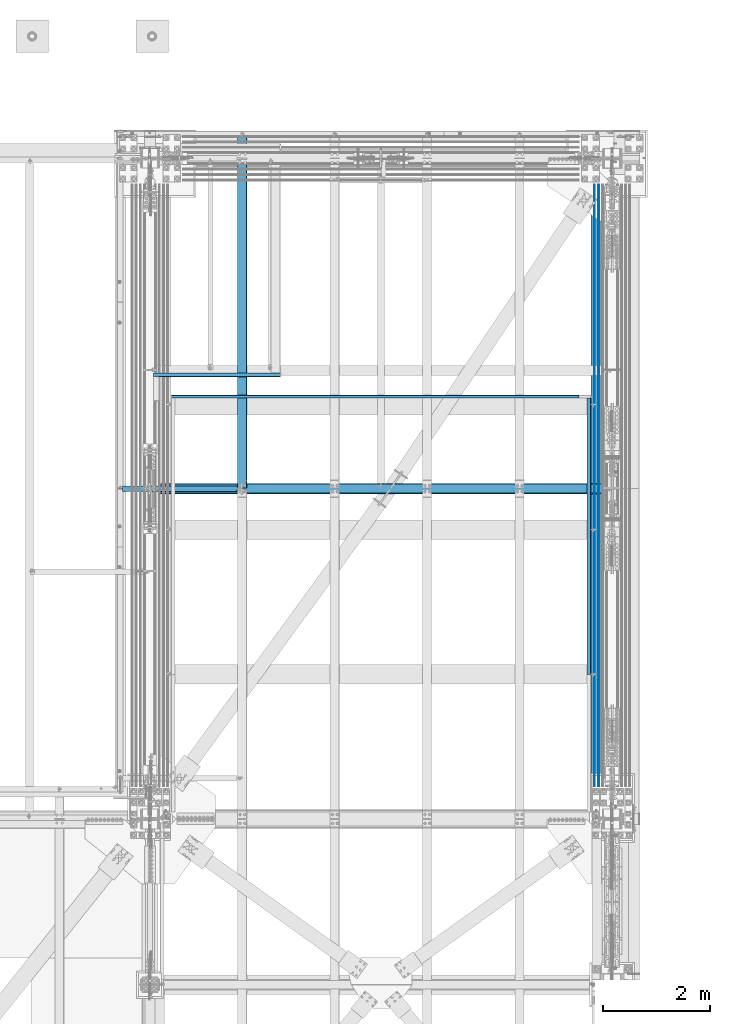
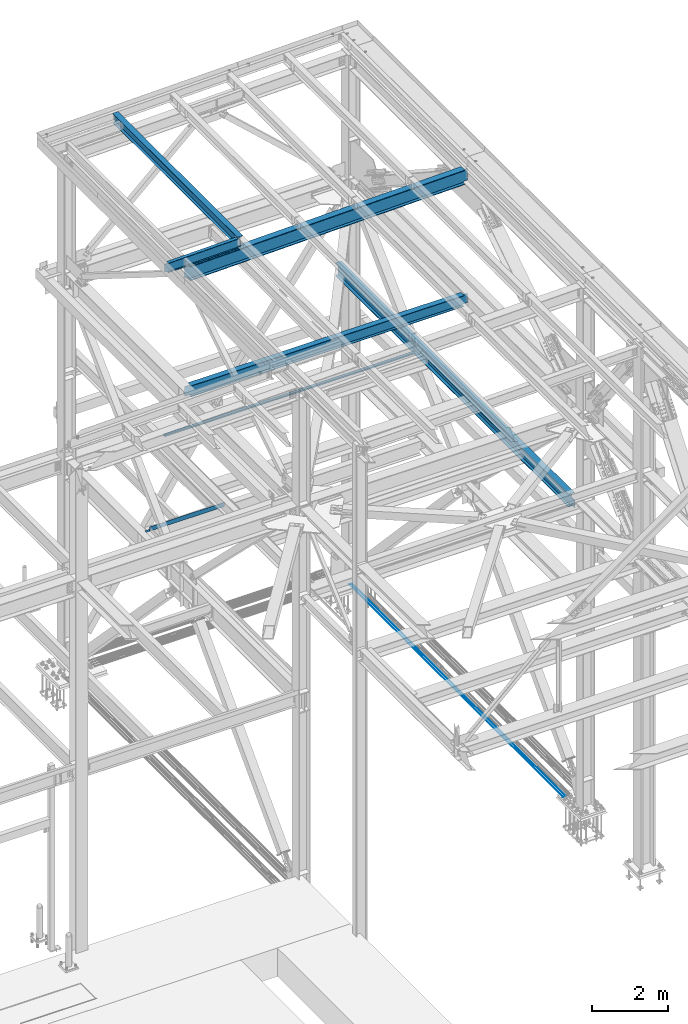
# One storey, part 1993 of 3843: 10 beams, 10 elements without a shape of their own.
"""IFC2X3 building model written with IfcOpenShell, lengths in millimetres."""

from ifc_helpers import new_model, si_unit, frame, origin_with_axes, place, context, subcontext, project, spatial, faceted_brep, material, type_object, element, aggregate, save


model = new_model("IFC2X3")

# Units and contexts
model_context = context("Model", 3, precision=1e-05, world=origin_with_axes())
body_context = subcontext(model_context, "Body", "Model", "MODEL_VIEW")
ifc_project = project(units=[si_unit("LENGTHUNIT", "METRE", prefix="MILLI"), si_unit("AREAUNIT", "SQUARE_METRE"), si_unit("VOLUMEUNIT", "CUBIC_METRE"), si_unit("MASSUNIT", "GRAM", prefix="KILO"), si_unit("TIMEUNIT", "SECOND"), si_unit("PLANEANGLEUNIT", "RADIAN"), si_unit("SOLIDANGLEUNIT", "STERADIAN"), si_unit("THERMODYNAMICTEMPERATUREUNIT", "DEGREE_CELSIUS"), si_unit("LUMINOUSINTENSITYUNIT", "LUMEN")], contexts=[model_context])

# Site, building, storey
site_placement = place(None, origin_with_axes())
site = spatial("IfcSite", under=ifc_project, at=site_placement, CompositionType="ELEMENT")
building_placement = place(site_placement, origin_with_axes())
building = spatial("IfcBuilding", under=site, at=building_placement, Name="Undefined", CompositionType="ELEMENT")
storey_placement = place(building_placement, origin_with_axes())
storey = spatial("IfcBuildingStorey", under=building, at=storey_placement, Name="Undefined", CompositionType="ELEMENT", Elevation=0.0)

# Assembly, beam
assembly_1_placement = place(storey_placement, origin_with_axes())
assembly_1 = element("IfcElementAssembly", 1, at=assembly_1_placement, inside=storey, Name="REBAR", AssemblyPlace="NOTDEFINED", PredefinedType="RIGID_FRAME")
ifc_material_1 = material(Name="STEEL/A706-60")
beam_type_1 = type_object("IfcBeamType", Name="#10 REBAR", PredefinedType="NOTDEFINED")
beam_1_placement = place(assembly_1_placement, frame((85318.6, 104063.800019533, 29700.5375), z_axis=(0.0, 0.0, 1.0), x_axis=(0.0, -1.0, 0.0)))
beam_1 = element("IfcBeam", 2, at=beam_1_placement, type_object=beam_type_1, material=ifc_material_1, Name="REBAR", ObjectType="#10 REBAR", context=body_context, shape_type="Brep", body=[
    faceted_brep([(0.0, -7.9375, 0.0), (0.0, -5.61266007566883, -5.61266007566883), (11239.5874999941, -5.61266007566883, -5.61266007566883), (11239.5874999941, -7.9375, 0.0), (0.0, 0.0, -7.9375), (11239.5874999941, 0.0, -7.9375), (0.0, 5.61266007566883, -5.61266007566883), (11239.5874999941, 5.61266007566883, -5.61266007566883), (0.0, 7.9375, 0.0), (11239.5874999941, 7.9375, 0.0), (0.0, 5.61266007566883, 5.61266007566883), (11239.5874999941, 5.61266007566883, 5.61266007566883), (0.0, 0.0, 7.9375), (11239.5874999941, 0.0, 7.9375), (0.0, -5.61266007566883, 5.61266007566883), (11239.5874999941, -5.61266007566883, 5.61266007566883)], [[[0, 1, 2, 3]], [[1, 4, 5, 2]], [[4, 6, 7, 5]], [[6, 8, 9, 7]], [[8, 10, 11, 9]], [[10, 12, 13, 11]], [[12, 14, 15, 13]], [[14, 0, 3, 15]], [[5, 7, 9, 11, 13, 15, 3, 2]], [[14, 12, 10, 8, 6, 4, 1, 0]]]),
])
aggregate(assembly_1, [beam_1])

assembly_2_placement = place(storey_placement, origin_with_axes())
assembly_2 = element("IfcElementAssembly", 3, at=assembly_2_placement, inside=storey, Name="REBAR", AssemblyPlace="NOTDEFINED", PredefinedType="RIGID_FRAME")
beam_2_placement = place(assembly_2_placement, frame((85394.8, 104063.800019533, 29700.5375), z_axis=(0.0, 0.0, 1.0), x_axis=(0.0, -1.0, 0.0)))
beam_2 = element("IfcBeam", 4, at=beam_2_placement, type_object=beam_type_1, material=ifc_material_1, Name="REBAR", ObjectType="#10 REBAR", context=body_context, shape_type="Brep", body=[
    faceted_brep([(0.0, -7.9375, 0.0), (0.0, -5.61266007566883, -5.61266007566883), (11239.5874999941, -5.61266007566883, -5.61266007566883), (11239.5874999941, -7.9375, 0.0), (0.0, 0.0, -7.9375), (11239.5874999941, 0.0, -7.9375), (0.0, 5.61266007566883, -5.61266007566883), (11239.5874999941, 5.61266007566883, -5.61266007566883), (0.0, 7.9375, 0.0), (11239.5874999941, 7.9375, 0.0), (0.0, 5.61266007566883, 5.61266007566883), (11239.5874999941, 5.61266007566883, 5.61266007566883), (0.0, 0.0, 7.9375), (11239.5874999941, 0.0, 7.9375), (0.0, -5.61266007566883, 5.61266007566883), (11239.5874999941, -5.61266007566883, 5.61266007566883)], [[[0, 1, 2, 3]], [[1, 4, 5, 2]], [[4, 6, 7, 5]], [[6, 8, 9, 7]], [[8, 10, 11, 9]], [[10, 12, 13, 11]], [[12, 14, 15, 13]], [[14, 0, 3, 15]], [[5, 7, 9, 11, 13, 15, 3, 2]], [[14, 12, 10, 8, 6, 4, 1, 0]]]),
])
aggregate(assembly_2, [beam_2])

assembly_3_placement = place(storey_placement, origin_with_axes())
assembly_3 = element("IfcElementAssembly", 5, at=assembly_3_placement, inside=storey, Name="BEAM", AssemblyPlace="NOTDEFINED", PredefinedType="RIGID_FRAME")
ifc_material_2 = material(Name="STEEL/A992")
beam_type_2 = type_object("IfcBeamType", Name="W12X26", PredefinedType="NOTDEFINED")
beam_3_placement = place(assembly_3_placement, frame((78736.7092624415, 98386.9000000014, 46465.9718519113), z_axis=(-0.0211520980073474, 0.0, 0.999776269347241), x_axis=(0.0, 1.0, 0.0)))
beam_3 = element("IfcBeam", 6, at=beam_3_placement, type_object=beam_type_2, material=ifc_material_2, Name="BEAM", ObjectType="W12X26", context=body_context, shape_type="Brep", body=[
    faceted_brep([(6589.71250002408, -3.17500000017753, -146.04999999977), (6589.71250002408, -82.5500000006141, -146.049999999697), (6589.71250002408, -82.5500000006286, -155.574999999684), (6589.71250002408, 82.5500000002939, -155.574999999822), (6589.71250002408, 82.5500000003085, -146.049999999836), (6589.71250002408, 3.17499999985739, -146.04999999977), (6589.71250002408, 3.17499999987194, -142.874999798943), (6589.71250002408, -3.17500000016298, -142.874999798936), (6590.67922994666, 3.17499999987194, -138.014920280926), (6590.67922994666, -3.17500000016298, -138.014920280919), (6593.43224384714, 3.17499999987194, -133.894743812787), (6593.43224384714, -3.17500000016298, -133.894743812787), (6597.5524203153, 3.1749999998865, -131.14172991232), (6597.5524203153, -3.17500000016298, -131.14172991232), (6602.41249983334, 3.17499999987194, -130.174999989737), (6602.41249983334, -3.17500000016298, -130.174999989737), (6659.56250002408, -3.17500000016298, -130.174999989766), (6659.56250002408, 3.17499999987194, -130.174999989766), (12.7000000064072, 3.17500000014843, 146.04999999977), (12.7000000064072, 82.5500000005995, 146.049999999697), (6589.71250002408, 82.5500000006141, 146.04999999969), (6589.71250002408, 3.17500000016298, 146.049999999763), (12.7000000064072, -82.5500000006432, -155.574999999677), (12.7000000064072, -82.5500000006141, -146.04999999969), (12.7000000064072, -3.17500000016298, -146.049999999763), (12.7000000064072, -3.17499999987194, 146.049999999777), (12.7000000064072, -82.5500000003231, 146.049999999836), (12.7000000064072, -82.5500000003231, 155.574999999822), (12.7000000064072, 82.5500000006141, 155.574999999684), (12.7000000064072, 3.17499999985739, -146.049999999763), (12.7000000064072, 82.5500000003085, -146.049999999828), (12.7000000064072, 82.5500000002939, -155.574999999815), (6589.71250002408, -3.17499999987194, 146.04999999977), (6589.71250002408, -82.5500000003231, 146.049999999828), (6589.71250002408, -82.5500000003231, 155.574999999815), (6589.71250002408, 82.5500000006141, 155.574999999677), (6589.71250002408, -3.1749999998865, 142.87499981821), (6589.71250002408, 3.17500000014843, 142.874999818203), (6590.67922994666, -3.1749999998865, 138.014920300186), (6590.67922994666, 3.17500000014843, 138.014920300178), (6593.43224384714, -3.17499999990105, 133.894743832054), (6593.43224384714, 3.17500000014843, 133.894743832047), (6597.5524203153, -3.1749999998865, 131.141729931587), (6597.5524203153, 3.17500000013388, 131.14172993158), (6602.41249983334, -3.1749999998865, 130.175000008996), (6602.41249983334, 3.17500000014843, 130.175000008996), (6659.56250002408, -3.1749999998865, 130.175000008967), (6659.56250002408, 3.17500000014843, 130.175000008967), (6659.56250002408, 3.1749999998865, -113.124999983287), (6659.56250002408, 3.17500000013388, 117.475000012979)], [[[0, 1, 2, 3, 4, 5, 6, 7]], [[7, 6, 8, 9]], [[9, 8, 10, 11]], [[11, 10, 12, 13]], [[13, 12, 14, 15]], [[16, 15, 14, 17]], [[18, 19, 20, 21]], [[22, 23, 24, 25, 26, 27, 28, 19, 18, 29, 30, 31]], [[26, 25, 32, 33]], [[27, 26, 33, 34]], [[28, 27, 34, 35]], [[19, 28, 35, 20]], [[34, 33, 32, 36, 37, 21, 20, 35]], [[38, 39, 37, 36]], [[40, 41, 39, 38]], [[42, 43, 41, 40]], [[44, 45, 43, 42]], [[46, 47, 45, 44]], [[48, 49, 47, 46, 16, 17]], [[12, 10, 8, 6, 5, 29, 18, 21, 37, 39, 41, 43, 45, 47, 49, 48, 17, 14]], [[30, 29, 5, 4]], [[31, 30, 4, 3]], [[22, 31, 3, 2]], [[23, 22, 2, 1]], [[24, 23, 1, 0]], [[46, 44, 42, 40, 38, 36, 32, 25, 24, 0, 7, 9, 11, 13, 15, 16]]]),
])
aggregate(assembly_3, [beam_3])

assembly_4_placement = place(storey_placement, origin_with_axes())
assembly_4 = element("IfcElementAssembly", 7, at=assembly_4_placement, inside=storey, Name="BEAM", AssemblyPlace="NOTDEFINED", PredefinedType="RIGID_FRAME")
beam_type_3 = type_object("IfcBeamType", Name="W12X19", PredefinedType="NOTDEFINED")
beam_4_placement = place(assembly_4_placement, frame((76406.4571586341, 98386.9000000001, 46418.258940625), z_axis=(-0.0211520980073474, 0.0, 0.999776269347241), x_axis=(0.999776270257024, 0.0, 0.0211520550054619)))
beam_4 = element("IfcBeam", 8, at=beam_4_placement, type_object=beam_type_3, material=ifc_material_2, Name="BEAM", ObjectType="W12X19", context=body_context, shape_type="Brep", body=[
    faceted_brep([(2232.3149825334, -3.17500000000291, -144.462499991867), (2232.3149825334, -50.8000000000029, -144.462499991867), (2232.31498253353, -50.8000000000029, -153.987499991876), (2232.31498253353, 50.8000000000029, -153.987499991876), (2232.3149825334, 50.8000000000029, -144.462499991867), (2232.3149825334, 3.17500000000291, -144.462499991867), (2232.31498253338, 3.17500000000291, -141.287499725579), (2232.31498253338, -3.17500000000291, -141.287499725579), (2233.28171245592, 3.17500000000291, -136.427420207467), (2233.28171245592, -3.17500000000291, -136.427420207467), (2236.03472635635, 3.17500000000291, -132.307243739255), (2236.03472635635, -3.17500000000291, -132.307243739255), (2240.15490282445, 3.17500000000291, -129.554229838737), (2240.15490282445, -3.17500000000291, -129.554229838737), (2245.01498234246, 3.17500000000291, -128.587499916146), (2245.01498234246, -3.17500000000291, -128.587499916146), (2314.86498100203, -3.17500000000291, -128.587499916357), (2314.86498100203, 3.17500000000291, -128.587499916357), (96.8374980314547, 3.17500000000291, 144.462500000489), (96.8374980314547, 50.8000000000029, 144.462500000489), (2232.31498253648, 50.8000000000029, 144.462500008405), (2232.31498253648, 3.17500000000291, 144.462500008405), (96.8374977455387, -3.17500000000291, -141.287499907492), (96.8374977455387, 3.17500000000291, -141.287499907492), (96.8374977423518, 3.17500000000291, -144.462499999776), (96.8374977423518, 50.8000000000029, -144.462499999776), (96.8374977328203, 50.8000000000029, -153.987499999792), (96.8374977328203, -50.8000000000029, -153.987499999792), (96.8374977423518, -50.8000000000029, -144.462499999776), (96.8374977423518, -3.17500000000291, -144.462499999776), (95.8707678278151, -3.17500000000291, -136.427420388471), (95.8707678278151, 3.17500000000291, -136.427420388471), (93.1177539315104, -3.17500000000291, -132.307243917545), (93.1177539315104, 3.17500000000291, -132.307243917545), (88.9975774661289, -3.17500000000291, -129.554230012938), (88.9975774661289, 3.17500000000291, -129.554230012938), (84.1374979491229, -3.17500000000291, -128.587500085479), (84.1374979491229, 3.17500000000291, -128.587500085479), (20.6374979119428, -3.17500000000291, -128.587500021946), (20.6374979119428, 3.17500000000291, -128.587500021946), (20.637499711811, -3.17500000000291, 128.587499979069), (20.637499711811, 3.17500000000291, 128.587499979069), (20.6374996229279, 3.17500000000291, 115.88750024372), (20.6374980090477, 3.17500000000291, -114.712499752241), (84.1374982064444, -3.17500000000291, 128.587499915513), (84.1374982064444, 3.17500000000291, 128.587499915513), (88.9975777254003, -3.17500000000291, 129.554229833244), (88.9975777254003, 3.17500000000291, 129.554229833244), (93.1177541962679, -3.17500000000291, 132.307243729607), (93.1177541962679, 3.17500000000291, 132.307243729607), (95.8707681008382, -3.17500000000291, 136.427420195025), (95.8707681008382, 3.17500000000291, 136.427420195025), (96.8374980282824, -3.17500000000291, 141.287499712118), (96.8374980282824, 3.17500000000291, 141.287499712118), (96.8374980410154, -50.8000000000029, 153.987499285155), (96.8374980410008, 50.8000000000029, 153.987500000498), (96.8374980314547, -3.17500000000291, 144.462500000489), (96.8374980314547, -50.8000000000029, 144.462500000489), (2232.31498253648, -3.17500000000291, 144.462500008405), (2232.31498253648, -50.8000000000029, 144.462500008405), (2232.31498253638, -50.8000000000029, 153.987499981791), (2232.31498253639, 50.8000000000029, 153.987500008421), (2232.31498253651, -3.17500000000291, 141.28749989366), (2232.31498253651, 3.17500000000291, 141.28749989366), (2233.28171245912, -3.17500000000291, 136.427420375658), (2233.28171245912, 3.17500000000291, 136.427420375658), (2236.03472635955, -3.17500000000291, 132.30724390754), (2236.03472635955, 3.17500000000291, 132.30724390754), (2240.15490282758, -3.17500000000291, 129.554230007096), (2240.15490282758, 3.17500000000291, 129.554230007096), (2245.0149823455, -3.17500000000291, 128.587500084504), (2245.0149823455, 3.17500000000291, 128.587500084504), (2314.86498280188, -3.17500000000291, 128.58750008425), (2314.86498280188, 3.17500000000291, 128.58750008425)], [[[0, 1, 2, 3, 4, 5, 6, 7]], [[7, 6, 8, 9]], [[9, 8, 10, 11]], [[11, 10, 12, 13]], [[13, 12, 14, 15]], [[16, 15, 14, 17]], [[18, 19, 20, 21]], [[22, 23, 24, 25, 26, 27, 28, 29]], [[30, 31, 23, 22]], [[32, 33, 31, 30]], [[34, 35, 33, 32]], [[36, 37, 35, 34]], [[38, 39, 37, 36]], [[40, 41, 42, 43, 39, 38]], [[44, 45, 41, 40]], [[46, 47, 45, 44]], [[48, 49, 47, 46]], [[50, 51, 49, 48]], [[52, 53, 51, 50]], [[54, 55, 19, 18, 53, 52, 56, 57]], [[57, 56, 58, 59]], [[54, 57, 59, 60]], [[55, 54, 60, 61]], [[19, 55, 61, 20]], [[60, 59, 58, 62, 63, 21, 20, 61]], [[64, 65, 63, 62]], [[66, 67, 65, 64]], [[68, 69, 67, 66]], [[70, 71, 69, 68]], [[72, 73, 71, 70]], [[73, 72, 16, 17]], [[12, 10, 8, 6, 5, 24, 23, 31, 33, 35, 37, 39, 43, 42, 41, 45, 47, 49, 51, 53, 18, 21, 63, 65, 67, 69, 71, 73, 17, 14]], [[25, 24, 5, 4]], [[26, 25, 4, 3]], [[27, 26, 3, 2]], [[28, 27, 2, 1]], [[29, 28, 1, 0]], [[72, 70, 68, 66, 64, 62, 58, 56, 52, 50, 48, 46, 44, 40, 38, 36, 34, 32, 30, 22, 29, 0, 7, 9, 11, 13, 15, 16]]]),
])
aggregate(assembly_4, [beam_4])

assembly_5_placement = place(storey_placement, origin_with_axes())
assembly_5 = element("IfcElementAssembly", 9, at=assembly_5_placement, inside=storey, Name="BEAM", AssemblyPlace="NOTDEFINED", PredefinedType="RIGID_FRAME")
beam_type_4 = type_object("IfcBeamType", Name="W18X65", PredefinedType="NOTDEFINED")
beam_5_placement = place(assembly_5_placement, frame((77017.7361060402, 98386.9, 46040.5792898826), z_axis=(-0.0211520980073474, 0.0, 0.999776269347241), x_axis=(0.999776270257024, 0.0, 0.0211520550054619)))
beam_5 = element("IfcBeam", 10, at=beam_5_placement, type_object=beam_type_4, material=ifc_material_2, Name="BEAM", ObjectType="W18X65", context=body_context, shape_type="Brep", body=[
    faceted_brep([(8477.59045331171, -5.55625000000146, -214.312499992448), (8477.59045331171, -96.8375000000015, -214.312499992448), (8477.59045331174, -96.8375000000015, -233.362499992414), (8477.59045331174, 96.8375000000015, -233.362499992414), (8477.59045331171, 96.8375000000015, -214.312499992448), (8477.59045331171, 5.55625000000146, -214.312499992448), (8477.5904533117, 5.55625000000146, -201.612499662813), (8477.5904533117, -5.55625000000146, -201.612499662813), (8478.5571832343, 5.55625000000146, -196.752420144789), (8478.5571832343, -5.55625000000146, -196.752420144789), (8481.31019713482, 5.55625000000146, -192.632243676657), (8481.31019713482, -5.55625000000146, -192.632243676657), (8485.43037360304, 5.55625000000146, -189.879229776183), (8485.43037360304, -5.55625000000146, -189.879229776183), (8490.29045312117, 5.55625000000146, -188.912499853599), (8490.29045312117, -5.55625000000146, -188.912499853599), (8608.35645144517, -5.55625000000146, -188.912499853563), (8608.35645144517, 5.55625000000146, -188.912499853563), (8483.94045331146, 96.8375000000015, 214.312500006869), (8483.94045331146, 5.55625000000146, 214.312500006869), (134.591986198662, 5.55625000000146, 214.312499999774), (134.591986198662, 96.8375000000015, 214.312499999774), (134.591986199128, -5.55625000000146, -163.51249980805), (134.591986199128, 5.55625000000146, -163.51249980805), (134.591986199172, 5.55625000000146, -214.312499999527), (134.591986199172, 96.8375000000015, -214.312499999527), (134.591986199201, 96.8375000000015, -233.362499999508), (134.591986199201, -96.8375000000015, -233.362499999508), (134.591986199172, -96.8375000000015, -214.312499999527), (134.591986199172, -5.55625000000146, -214.312499999527), (133.625256276515, -5.55625000000146, -158.652420290033), (133.625256276515, 5.55625000000146, -158.652420290033), (130.87224237599, -5.55625000000146, -154.532243821901), (130.87224237599, 5.55625000000146, -154.532243821901), (126.752065907756, -5.55625000000146, -151.779229921442), (126.752065907756, 5.55625000000146, -151.779229921442), (121.89198638963, -5.55625000000146, -150.81249999885), (121.89198638963, 5.55625000000146, -150.81249999885), (9.33848262824176, -5.55625000000146, -150.812499998887), (9.33848262824176, 5.55625000000146, -150.812499998887), (16.7946789481648, -5.55625000000146, 201.61249999921), (16.7946789481648, 5.55625000000146, 201.61249999921), (16.1369776922947, 5.55625000000146, 170.525554973312), (9.64751402361435, 5.55625000000146, -136.205804461417), (121.891986389208, -5.55625000000146, 201.612499999304), (121.891986389208, 5.55625000000146, 201.612499999304), (126.75206590732, -5.55625000000146, 202.579229921888), (126.75206590732, 5.55625000000146, 202.579229921888), (130.872242375539, -5.55625000000146, 205.332243822348), (130.872242375539, 5.55625000000146, 205.332243822348), (133.625256276049, -5.55625000000146, 209.452420290487), (133.625256276049, 5.55625000000146, 209.452420290487), (134.591986198662, -5.55625000000146, 214.312499999774), (134.591986198648, -96.8375000000015, 233.362499999748), (134.591986198648, 96.8375000000015, 233.362499999748), (134.591986198662, -96.8375000000015, 214.312499999774), (8483.94045331146, -5.55625000000146, 214.312500006869), (8483.94045331146, -96.8375000000015, 214.312500006869), (8483.94045331144, -96.8375000000015, 233.362500006835), (8483.94045331144, 96.8375000000015, 233.362500006835), (8483.94045331149, -5.55625000000146, 201.612499953568), (8483.94045331149, 5.55625000000146, 201.612499953568), (8484.9071832341, -5.55625000000146, 196.752420435558), (8484.9071832341, 5.55625000000146, 196.752420435558), (8487.66019713462, -5.55625000000146, 192.632243967419), (8487.66019713462, 5.55625000000146, 192.632243967419), (8491.78037360284, -5.55625000000146, 189.879230066967), (8491.78037360284, 5.55625000000146, 189.879230066967), (8496.64045312097, -5.55625000000146, 188.912500144383), (8496.64045312097, 5.55625000000146, 188.912500144383), (8616.35003128365, -5.55625000000146, 188.912500144485), (8616.35003128365, 5.55625000000146, 188.912500144485), (8609.71183290241, 5.55625000000146, -124.848962686272), (8616.2012965711, 5.55625000000146, 181.882396748464)], [[[0, 1, 2, 3, 4, 5, 6, 7]], [[7, 6, 8, 9]], [[9, 8, 10, 11]], [[11, 10, 12, 13]], [[13, 12, 14, 15]], [[16, 15, 14, 17]], [[18, 19, 20, 21]], [[22, 23, 24, 25, 26, 27, 28, 29]], [[30, 31, 23, 22]], [[32, 33, 31, 30]], [[34, 35, 33, 32]], [[36, 37, 35, 34]], [[38, 39, 37, 36]], [[40, 41, 42, 43, 39, 38]], [[44, 45, 41, 40]], [[46, 47, 45, 44]], [[48, 49, 47, 46]], [[50, 51, 49, 48]], [[52, 20, 51, 50]], [[53, 54, 21, 20, 52, 55]], [[56, 57, 55, 52]], [[57, 58, 53, 55]], [[58, 59, 54, 53]], [[59, 18, 21, 54]], [[58, 57, 56, 60, 61, 19, 18, 59]], [[62, 63, 61, 60]], [[64, 65, 63, 62]], [[66, 67, 65, 64]], [[68, 69, 67, 66]], [[70, 71, 69, 68]], [[72, 73, 71, 70, 16, 17]], [[33, 35, 37, 39, 43, 42, 41, 45, 47, 49, 51, 20, 19, 61, 63, 65, 67, 69, 71, 73, 72, 17, 14, 12, 10, 8, 6, 5, 24, 23, 31]], [[5, 4, 25, 24]], [[4, 3, 26, 25]], [[3, 2, 27, 26]], [[2, 1, 28, 27]], [[1, 0, 29, 28]], [[0, 7, 9, 11, 13, 15, 16, 70, 68, 66, 64, 62, 60, 56, 52, 50, 48, 46, 44, 40, 38, 36, 34, 32, 30, 22, 29]]]),
])
aggregate(assembly_5, [beam_5])

assembly_6_placement = place(storey_placement, origin_with_axes())
assembly_6 = element("IfcElementAssembly", 11, at=assembly_6_placement, inside=storey, Name="BENT_PLATE", AssemblyPlace="NOTDEFINED", PredefinedType="RIGID_FRAME")
ifc_material_3 = material(Name="STEEL/A36")
beam_type_5 = type_object("IfcBeamType", PredefinedType="NOTDEFINED")
beam_6_placement = place(assembly_6_placement, frame((85177.3127500008, 97499.090384, 39627.1750000002), z_axis=(0.0, 1.0, 0.0), x_axis=(1.0, 0.0, 0.0)))
beam_6 = element("IfcBeam", 12, at=beam_6_placement, type_object=beam_type_5, material=ifc_material_3, Name="BENT_PLATE", context=body_context, shape_type="Brep", body=[
    faceted_brep([(0.0, -3.17500000000291, -2583.6565), (0.0, -3.17500000000291, 2583.6565), (0.0, 3.17500000000291, 2583.6565), (0.0, 3.17500000000291, -2583.6565), (76.1999999995169, 3.17500000000291, 2583.6565), (76.1999999995169, 3.17500000000291, -2583.6565), (69.8499999995256, -3.17500000000291, -2583.6565), (69.8499999995256, -3.17500000000291, 2583.6565), (76.1999999996042, -73.0250000004817, 2583.6565), (76.1999999996042, -73.0250000004817, -2583.6565), (69.8499999995984, -73.0250000004962, 2583.6565), (69.8499999995984, -73.0250000004962, -2583.6565)], [[[0, 1, 2, 3]], [[3, 2, 4, 5]], [[1, 0, 6, 7]], [[5, 4, 8, 9]], [[4, 2, 1, 7, 10, 8]], [[7, 6, 11, 10]], [[6, 0, 3, 5, 9, 11]], [[10, 11, 9, 8]]]),
])
aggregate(assembly_6, [beam_6])

assembly_7_placement = place(storey_placement, origin_with_axes())
assembly_7 = element("IfcElementAssembly", 13, at=assembly_7_placement, inside=storey, Name="BEAM", AssemblyPlace="NOTDEFINED", PredefinedType="RIGID_FRAME")
beam_type_6 = type_object("IfcBeamType", PredefinedType="NOTDEFINED")
beam_7_placement = place(assembly_7_placement, frame((81218.08725, 100082.746884, 39627.175), z_axis=(-1.0, 0.0, 0.0), x_axis=(0.0, 1.0, 0.0)))
beam_7 = element("IfcBeam", 14, at=beam_7_placement, type_object=beam_type_6, material=ifc_material_3, Name="BENT_PLATE", context=body_context, shape_type="Brep", body=[
    faceted_brep([(0.0, -3.17500000000291, -3810.0), (0.0, -3.17500000000291, 3810.0), (0.0, 3.17500000000291, 3810.0), (0.0, 3.17500000000291, -3810.0), (50.7999999999884, 3.17500000000291, 3810.0), (50.7999999999884, 3.17500000000291, -3810.0), (44.4499999999825, -3.17500000000291, -3810.0), (44.4499999999825, -3.17500000000291, 3810.0), (50.7999999999884, -73.0249999999942, 3810.0), (50.7999999999884, -73.0249999999942, -3810.0), (44.4499999999825, -73.0249999999942, 3810.0), (44.4499999999825, -73.0249999999942, -3810.0)], [[[0, 1, 2, 3]], [[3, 2, 4, 5]], [[1, 0, 6, 7]], [[5, 4, 8, 9]], [[4, 2, 1, 7, 10, 8]], [[7, 6, 11, 10]], [[6, 0, 3, 5, 9, 11]], [[10, 11, 9, 8]]]),
])
aggregate(assembly_7, [beam_7])

assembly_8_placement = place(storey_placement, origin_with_axes())
assembly_8 = element("IfcElementAssembly", 15, at=assembly_8_placement, inside=storey, Name="BEAM", AssemblyPlace="NOTDEFINED", PredefinedType="RIGID_FRAME")
beam_type_7 = type_object("IfcBeamType", PredefinedType="NOTDEFINED")
beam_8_placement = place(assembly_8_placement, frame((78263.7492498977, 100552.265593747, 36439.475), z_axis=(-0.999999999913893, -1.31230000260984e-05, 0.0), x_axis=(1.31230000327987e-05, -0.999999999913893, 0.0)))
beam_8 = element("IfcBeam", 16, at=beam_8_placement, type_object=beam_type_7, material=ifc_material_3, Name="BENT_PLATE", context=body_context, shape_type="Brep", body=[
    faceted_brep([(76.2000004328729, 136.524999577916, 1079.50024489472), (69.8500004328671, 136.524999577916, 1079.50016156367), (69.8500004328234, 3.17500000000291, 1079.50016156367), (76.2000004328584, 3.17500000001019, 1079.50024489472), (76.2000004201691, 3.17500000002474, 1188.24449996973), (69.8500004332891, 3.17500000000291, 1188.24349999827), (-5.15137799084187e-09, 3.17500000000291, -1188.24349999857), (-5.15137799084187e-09, -3.17500000000291, -1188.24349999857), (5.16592990607023e-09, -3.17500000000291, 1188.24349999857), (5.16592990607023e-09, 3.17500000000291, 1188.24349999857), (4.70026861876249e-09, 3.17500000000291, 1079.4992449221), (76.2000004231086, -3.17500000000291, -1188.24349999891), (69.8500004231028, 3.17500000000291, -1188.24349999888), (69.8500004230591, 136.52499957804, -1188.24349999886), (76.2000004230649, 136.52499957804, -1188.24349999889), (76.2000004332949, -3.17500000000291, 1188.24349999825)], [[[0, 1, 2, 3]], [[4, 3, 2, 5]], [[6, 7, 8, 9, 10]], [[11, 7, 6, 12, 13, 14]], [[8, 7, 11, 15]], [[9, 8, 15, 4, 5]], [[6, 10, 9, 5, 2, 12]], [[13, 12, 2, 1]], [[14, 13, 1, 0]], [[15, 11, 14, 0, 3, 4]]]),
])
aggregate(assembly_8, [beam_8])

assembly_9_placement = place(storey_placement, origin_with_axes())
assembly_9 = element("IfcElementAssembly", 17, at=assembly_9_placement, inside=storey, Name="BEAM", AssemblyPlace="NOTDEFINED", PredefinedType="RIGID_FRAME")
beam_type_8 = type_object("IfcBeamType", Name="W14X34", PredefinedType="NOTDEFINED")
beam_9_placement = place(assembly_9_placement, frame((77012.8, 98386.9, 42246.55), z_axis=(0.0, 0.0, 1.0), x_axis=(1.0, 0.0, 0.0)))
beam_9 = element("IfcBeam", 18, at=beam_9_placement, type_object=beam_type_8, material=ifc_material_2, Name="BEAM", ObjectType="W14X34", context=body_context, shape_type="Brep", body=[
    faceted_brep([(19.0500000000029, -3.96875, -152.400000000009), (19.0500000000029, 3.96875, -152.400000000009), (158.750000190747, 3.96888814302292, -152.400000000009), (158.750000190747, -3.96875, -152.400000000009), (163.610079708786, 3.96888886103261, -153.3667299226), (163.610079708786, -3.96875, -153.3667299226), (167.730256176947, 3.96889090164768, -156.119743823074), (167.730256176947, -3.96875, -156.119743823074), (170.483270077428, 3.96889395419566, -160.239920291227), (170.483270077428, -3.96875, -160.239920291227), (171.450000000012, -3.96875, -165.099999809274), (171.450000000012, 3.96889755396114, -165.099999809274), (171.450000000012, 3.96924972475972, -166.6875), (171.450000000012, 85.7249999999985, -166.6875), (171.450000000012, 85.7249999999985, -177.800000000003), (171.450000000012, -85.7249999999985, -177.800000000003), (171.450000000012, -85.7249999999985, -166.6875), (171.450000000012, -3.96875, -166.6875), (8464.55, 85.7249999999985, 166.6875), (8464.55, 3.96875, 166.6875), (171.450000000012, 3.96875, 166.6875), (171.450000000012, 85.7249999999985, 166.6875), (158.750000190747, -3.96875, 152.399999999994), (158.750000190747, 3.96866536417292, 152.399999999994), (19.0500000000029, 3.96875, 152.399999999994), (19.0500000000029, -3.96875, 152.399999999994), (163.610079708786, -3.96875, 153.366729922585), (163.610079708786, 3.96866465111816, 153.366729922585), (167.730256176947, -3.96875, 156.119743823059), (167.730256176947, 3.96866262051844, 156.119743823059), (170.483270077428, -3.96875, 160.239920291213), (170.483270077428, 3.96865958151466, 160.239920291213), (171.450000000012, -3.96875, 165.099999809259), (171.450000000012, 3.96865599675948, 165.099999809259), (8464.55, -85.7249999999985, 177.800000000003), (8464.55, 85.7249999999985, 177.800000000003), (171.450000000012, 85.7249999999985, 177.800000000003), (171.450000000012, -85.7249999999985, 177.800000000003), (8464.55, -85.7249999999985, 166.6875), (171.450000000012, -85.7249999999985, 166.6875), (8464.55, -3.96875, 166.6875), (171.450000000012, -3.96875, 166.6875), (8464.55, -3.96875, 165.099999809274), (8464.55, 3.96868980448926, 165.099999809274), (8465.51672992259, -3.96875, 160.239920291227), (8465.51672992259, 3.96869344847801, 160.239920291227), (8468.26974382307, -3.96875, 156.119743823074), (8468.26974382307, 3.96869653770409, 156.119743823074), (8472.38992029123, -3.96875, 153.3667299226), (8472.38992029123, 3.96869860186416, 153.3667299226), (8477.24999980927, -3.96875, 152.400000000009), (8477.24999980927, 3.96869932669506, 152.400000000009), (8616.95, -3.96875, 152.400000000009), (8616.95, 3.96875, 152.400000000009), (8616.95, -3.96875, -152.399999999994), (8616.95, 3.96875, -152.399999999994), (8477.24999980927, -3.96875, -152.399999999994), (8477.24999980927, 3.96892679322627, -152.399999999994), (8472.38992029123, -3.96875, -153.366729922585), (8472.38992029123, 3.96892752130225, -153.366729922585), (8468.26974382307, -3.96875, -156.119743823059), (8468.26974382307, 3.9689295921271, -156.119743823059), (8465.51672992259, -3.96875, -160.239920291213), (8465.51672992259, 3.96893269044813, -160.239920291213), (8464.55, -3.96875, -165.099999809259), (8464.55, 3.96893634455046, -165.099999809259), (8464.55, -3.96875, -166.6875), (8464.55, -85.7249999999985, -166.6875), (8464.55, -85.7249999999985, -177.800000000003), (8464.55, 85.7249999999985, -177.800000000003), (8464.55, 85.7249999999985, -166.6875), (8464.55, 3.96875, -166.6875)], [[[0, 1, 2, 3]], [[3, 2, 4, 5]], [[5, 4, 6, 7]], [[7, 6, 8, 9]], [[10, 11, 12, 13, 14, 15, 16, 17]], [[9, 8, 11, 10]], [[18, 19, 20, 21]], [[22, 23, 24, 25]], [[26, 27, 23, 22]], [[28, 29, 27, 26]], [[30, 31, 29, 28]], [[32, 33, 31, 30]], [[34, 35, 36, 37]], [[38, 34, 37, 39]], [[40, 38, 39, 41]], [[37, 36, 21, 20, 33, 32, 41, 39]], [[35, 18, 21, 36]], [[34, 38, 40, 42, 43, 19, 18, 35]], [[44, 45, 43, 42]], [[46, 47, 45, 44]], [[48, 49, 47, 46]], [[50, 51, 49, 48]], [[52, 53, 51, 50]], [[53, 52, 54, 55]], [[54, 56, 57, 55]], [[58, 59, 57, 56]], [[60, 61, 59, 58]], [[62, 63, 61, 60]], [[64, 65, 63, 62]], [[66, 67, 68, 69, 70, 71, 65, 64]], [[67, 66, 17, 16]], [[68, 67, 16, 15]], [[69, 68, 15, 14]], [[70, 69, 14, 13]], [[71, 70, 13, 12]], [[6, 4, 2, 1, 24, 23, 27, 29, 31, 33, 20, 19, 43, 45, 47, 49, 51, 53, 55, 57, 59, 61, 63, 65, 71, 12, 11, 8]], [[25, 24, 1, 0]], [[66, 64, 62, 60, 58, 56, 54, 52, 50, 48, 46, 44, 42, 40, 41, 32, 30, 28, 26, 22, 25, 0, 3, 5, 7, 9, 10, 17]]]),
])
aggregate(assembly_9, [beam_9])

assembly_10_placement = place(storey_placement, origin_with_axes())
assembly_10 = element("IfcElementAssembly", 19, at=assembly_10_placement, inside=storey, Name="BEAM", AssemblyPlace="NOTDEFINED", PredefinedType="RIGID_FRAME")
beam_type_9 = type_object("IfcBeamType", Name="W16X57", PredefinedType="NOTDEFINED")
beam_10_placement = place(assembly_10_placement, frame((85344.0, 92214.7, 39476.3625), z_axis=(0.0, 0.0, 1.0), x_axis=(0.0, 1.0, 0.0)))
beam_10 = element("IfcBeam", 20, at=beam_10_placement, type_object=beam_type_9, material=ifc_material_2, Name="BEAM", ObjectType="W16X57", context=body_context, shape_type="Brep", body=[
    faceted_brep([(18.2562499999767, -5.55624999999418, -157.162499999999), (18.2562499999767, 5.55624999999418, -157.162499999999), (196.056250190712, 5.55624999999418, -157.162499999999), (196.056250190712, -5.55624999999418, -157.162499999999), (200.916329708751, 5.55624999999418, -158.12922992259), (200.916329708751, -5.55624999999418, -158.12922992259), (205.036506176912, 5.55624999999418, -160.882243823064), (205.036506176912, -5.55624999999418, -160.882243823064), (207.789520077393, 5.55624999999418, -165.002420291217), (207.789520077393, -5.55624999999418, -165.002420291217), (208.756249999977, -5.55624999999418, -169.862499809264), (208.756249999977, 5.55624999999418, -169.862499809264), (208.756249999977, 5.55624999999418, -190.5), (208.756249999977, 90.4875000000029, -190.5), (208.756249999977, 90.4875000000029, -207.962500000001), (208.756249999977, -90.4875000000029, -207.962500000001), (208.756249999977, -90.4875000000029, -190.5), (208.756249999977, -5.55624999999418, -190.5), (12471.4, -90.4875000000029, 190.5), (12471.4, -90.4875000000029, 207.962500000001), (208.756249999977, -90.4875000000029, 207.962500000001), (208.756249999977, -90.4875000000029, 190.5), (12471.4, 90.4875000000029, 207.962500000001), (208.756249999977, 90.4875000000029, 207.962500000001), (12471.4, 90.4875000000029, 190.5), (208.756249999977, 90.4875000000029, 190.5), (12471.4, 5.55624999999418, 190.5), (208.756249999977, 5.55624999999418, 190.5), (196.056250190712, -5.55624999999418, 93.6624999999985), (196.056250190712, 5.55624999999418, 93.6624999999985), (18.2562499999767, 5.55624999999418, 93.6624999999985), (18.2562499999767, -5.55624999999418, 93.6624999999985), (200.916329708751, -5.55624999999418, 94.6292299225897), (200.916329708751, 5.55624999999418, 94.6292299225897), (205.036506176912, -5.55624999999418, 97.3822438230636), (205.036506176912, 5.55624999999418, 97.3822438230636), (207.789520077393, -5.55624999999418, 101.502420291217), (207.789520077393, 5.55624999999418, 101.502420291217), (208.756249999977, -5.55624999999418, 106.362499809264), (208.756249999977, 5.55624999999418, 106.362499809264), (208.756249999977, -5.55624999999418, 190.5), (12471.4, -5.55624999999418, 190.5), (12471.4, 5.55624999999418, -190.5), (12471.4, -5.55624999999418, -190.5), (12471.4, -90.4875000000029, -190.5), (12471.4, -90.4875000000029, -207.962500000001), (12471.4, 90.4875000000029, -207.962500000001), (12471.4, 90.4875000000029, -190.5), (18.2562499999767, -5.55624999999418, -136.9375)], [[[0, 1, 2, 3]], [[3, 2, 4, 5]], [[5, 4, 6, 7]], [[7, 6, 8, 9]], [[10, 11, 12, 13, 14, 15, 16, 17]], [[9, 8, 11, 10]], [[18, 19, 20, 21]], [[19, 22, 23, 20]], [[22, 24, 25, 23]], [[24, 26, 27, 25]], [[28, 29, 30, 31]], [[32, 33, 29, 28]], [[34, 35, 33, 32]], [[36, 37, 35, 34]], [[38, 39, 37, 36]], [[20, 23, 25, 27, 39, 38, 40, 21]], [[41, 18, 21, 40]], [[42, 26, 24, 22, 19, 18, 41, 43, 44, 45, 46, 47]], [[44, 43, 17, 16]], [[45, 44, 16, 15]], [[46, 45, 15, 14]], [[47, 46, 14, 13]], [[42, 47, 13, 12]], [[6, 4, 2, 1, 30, 29, 33, 35, 37, 39, 27, 26, 42, 12, 11, 8]], [[48, 31, 30, 1, 0]], [[43, 41, 40, 38, 36, 34, 32, 28, 31, 48, 0, 3, 5, 7, 9, 10, 17]]]),
])
aggregate(assembly_10, [beam_10])

save(model, "model.ifc")
